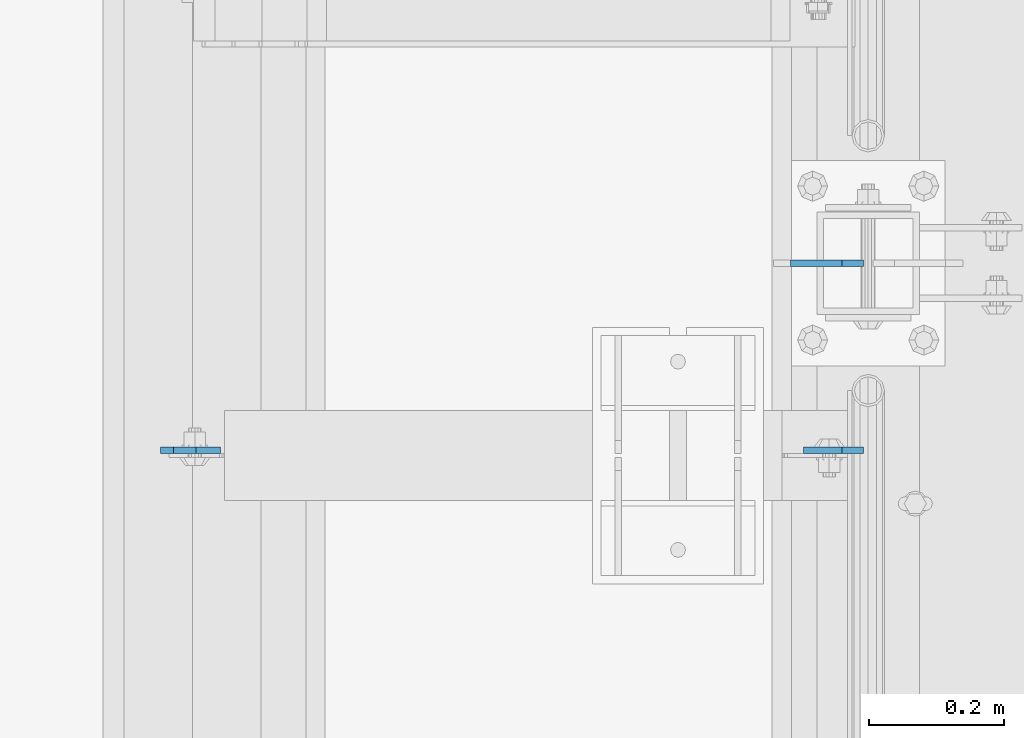
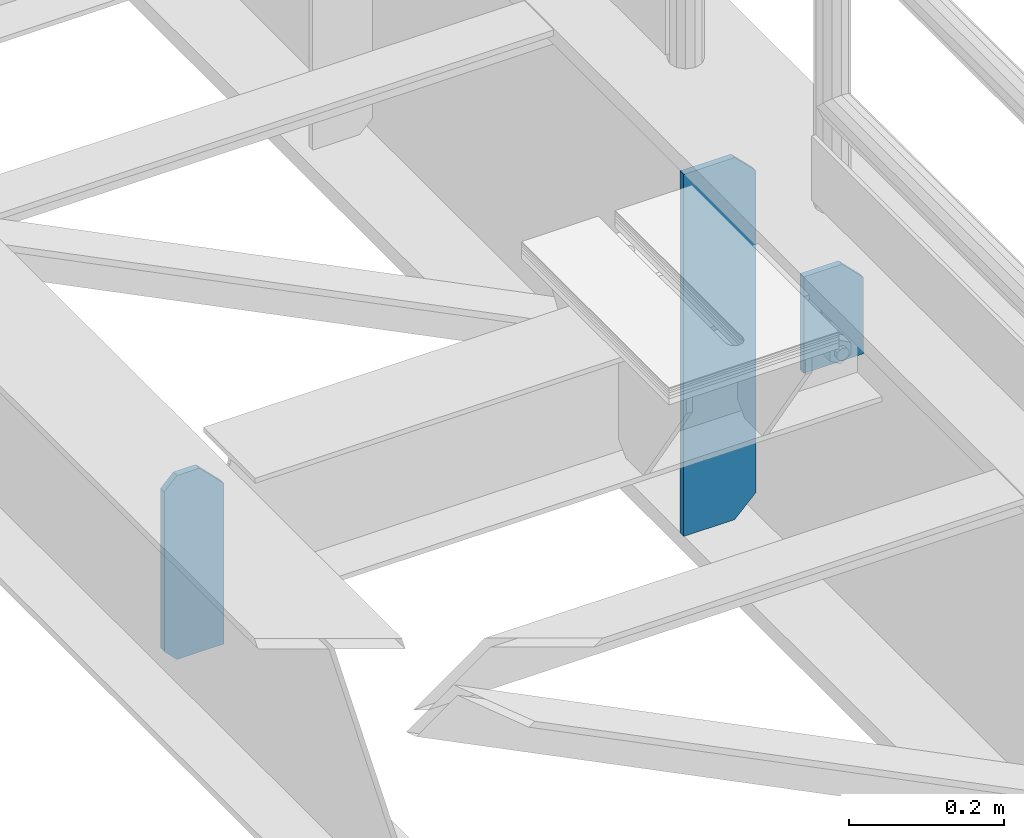
# One storey, part 1744 of 1876: 3 plates, 2 elements without a shape of their own.
"""IFC2X3 building model written with IfcOpenShell, lengths in millimetres."""

from ifc_helpers import new_model, si_unit, frame, origin_with_axes, place, context, subcontext, project, spatial, faceted_brep, material, type_object, element, aggregate, save


model = new_model("IFC2X3")

# Units and contexts
model_context = context("Model", 3, precision=1e-05, world=origin_with_axes())
body_context = subcontext(model_context, "Body", "Model", "MODEL_VIEW")
ifc_project = project(units=[si_unit("LENGTHUNIT", "METRE", prefix="MILLI"), si_unit("AREAUNIT", "SQUARE_METRE"), si_unit("VOLUMEUNIT", "CUBIC_METRE"), si_unit("MASSUNIT", "GRAM", prefix="KILO"), si_unit("TIMEUNIT", "SECOND"), si_unit("PLANEANGLEUNIT", "RADIAN"), si_unit("SOLIDANGLEUNIT", "STERADIAN"), si_unit("THERMODYNAMICTEMPERATUREUNIT", "DEGREE_CELSIUS"), si_unit("LUMINOUSINTENSITYUNIT", "LUMEN")], contexts=[model_context])

# Site, building, storey
site_placement = place(None, origin_with_axes())
site = spatial("IfcSite", under=ifc_project, at=site_placement, CompositionType="ELEMENT")
building_placement = place(site_placement, origin_with_axes())
building = spatial("IfcBuilding", under=site, at=building_placement, Name="Undefined", CompositionType="ELEMENT")
storey_placement = place(building_placement, origin_with_axes())
storey = spatial("IfcBuildingStorey", under=building, at=storey_placement, Name="Undefined", CompositionType="ELEMENT", Elevation=0.0)

# Assembly, plate
assembly_1_placement = place(storey_placement, origin_with_axes())
assembly_1 = element("IfcElementAssembly", 1, at=assembly_1_placement, inside=storey, Name="BEAM", AssemblyPlace="NOTDEFINED", PredefinedType="RIGID_FRAME")
ifc_material = material(Name="STEEL/A36")
plate_type_1 = type_object("IfcPlateType", PredefinedType="NOTDEFINED")
plate_1_placement = place(assembly_1_placement, frame((7612.85625, 9374.18799991608, 4953.0), z_axis=(0.0, 0.0, 1.0), x_axis=(-1.0, 0.0, 0.0)))
plate_1 = element("IfcPlate", 2, at=plate_1_placement, type_object=plate_type_1, material=ifc_material, Name="PLATE", context=body_context, shape_type="Brep", body=[
    faceted_brep([(0.0, -4.76249999999982, 0.0), (0.0, -4.76250000000073, 120.649993896484), (0.0, 4.76250000000073, 120.649993896484), (0.0, 4.76249999999982, 0.0), (31.75, -4.76250000000073, 152.399993896484), (31.75, 4.76250000000073, 152.399993896484), (88.9000015258789, -4.76250000000073, 152.399993896484), (88.9000015258789, 4.76250000000073, 152.399993896484), (88.9000015258789, -4.76249999999982, 0.0), (88.9000015258789, 4.76249999999982, 0.0)], [[[0, 1, 2, 3]], [[1, 4, 5, 2]], [[4, 6, 7, 5]], [[6, 8, 9, 7]], [[8, 0, 3, 9]], [[5, 7, 9, 3, 2]], [[8, 6, 4, 1, 0]]]),
])

assembly_2_placement = place(storey_placement, origin_with_axes())
assembly_2 = element("IfcElementAssembly", 3, at=assembly_2_placement, inside=storey, Name="BEAM", AssemblyPlace="NOTDEFINED", PredefinedType="RIGID_FRAME")
plate_2_placement = place(assembly_2_placement, frame((6569.075, 9374.18799991608, 4829.175), z_axis=(0.0, 0.0, 1.0), x_axis=(1.0, 0.0, 0.0)))
plate_2 = element("IfcPlate", 4, at=plate_2_placement, type_object=plate_type_1, material=ifc_material, Name="PLATE", context=body_context, shape_type="Brep", body=[
    faceted_brep([(0.0, -4.76249999999982, 271.462512969971), (19.0499992370605, -4.76249999999982, 290.512512207031), (19.0499992370605, 4.76249999999982, 290.512512207031), (0.0, 4.76249999999982, 271.462512969971), (0.0, -4.76249999999982, 19.0499992370605), (0.0, 4.76249999999982, 19.0499992370605), (19.0499992370605, -4.76249999999982, 0.0), (19.0499992370605, 4.76249999999982, 0.0), (88.9000015258789, -4.76249999999982, 0.0), (88.9000015258789, 4.76249999999982, 0.0), (88.9000015258789, -4.76250000000073, 254.000007629395), (52.3874896739244, -4.76250000000073, 290.512512207031), (52.3874896739244, 4.76250000000073, 290.512512207031), (88.9000015258789, 4.76250000000073, 254.000007629395)], [[[0, 1, 2, 3]], [[4, 0, 3, 5]], [[6, 4, 5, 7]], [[8, 6, 7, 9]], [[1, 0, 4, 6, 8, 10, 11]], [[2, 1, 11, 12]], [[9, 7, 5, 3, 2, 12, 13]], [[10, 8, 9, 13]], [[12, 11, 10, 13]]]),
])
aggregate(assembly_2, [plate_2])

# Plate
plate_type_2 = type_object("IfcPlateType", PredefinedType="NOTDEFINED")
plate_3_placement = place(assembly_1_placement, frame((7612.85625, 9652.0, 4533.9), z_axis=(0.0, 0.0, 1.0), x_axis=(-1.0, 0.0, 0.0)))
plate_3 = element("IfcPlate", 5, at=plate_3_placement, type_object=plate_type_2, material=ifc_material, Name="PLATE", context=body_context, shape_type="Brep", body=[
    faceted_brep([(-9.76996261670138e-14, -4.76250000000073, 31.75), (0.0, -4.76249999999982, 539.75), (0.0, 4.76249999999982, 539.75), (-9.76996261670138e-14, 4.76250000000073, 31.75), (31.75, -4.76249999999982, 571.5), (31.75, 4.76249999999982, 571.5), (107.949996948242, -4.76249999999982, 571.5), (107.949996948242, 4.76249999999982, 571.5), (107.950006484985, -4.76250000000073, 0.0), (107.950006484985, 4.76250000000073, 0.0), (31.75, -4.76250000000073, 0.0), (31.75, 4.76250000000073, 0.0)], [[[0, 1, 2, 3]], [[1, 4, 5, 2]], [[4, 6, 7, 5]], [[6, 8, 9, 7]], [[8, 10, 11, 9]], [[10, 0, 3, 11]], [[5, 7, 9, 11, 3, 2]], [[10, 8, 6, 4, 1, 0]]]),
])

aggregate(assembly_1, [plate_3, plate_1])

save(model, "model.ifc")
